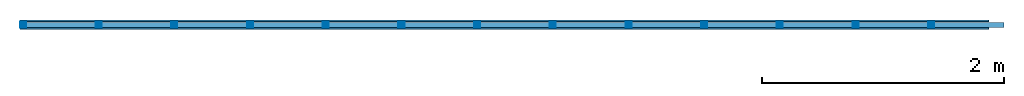
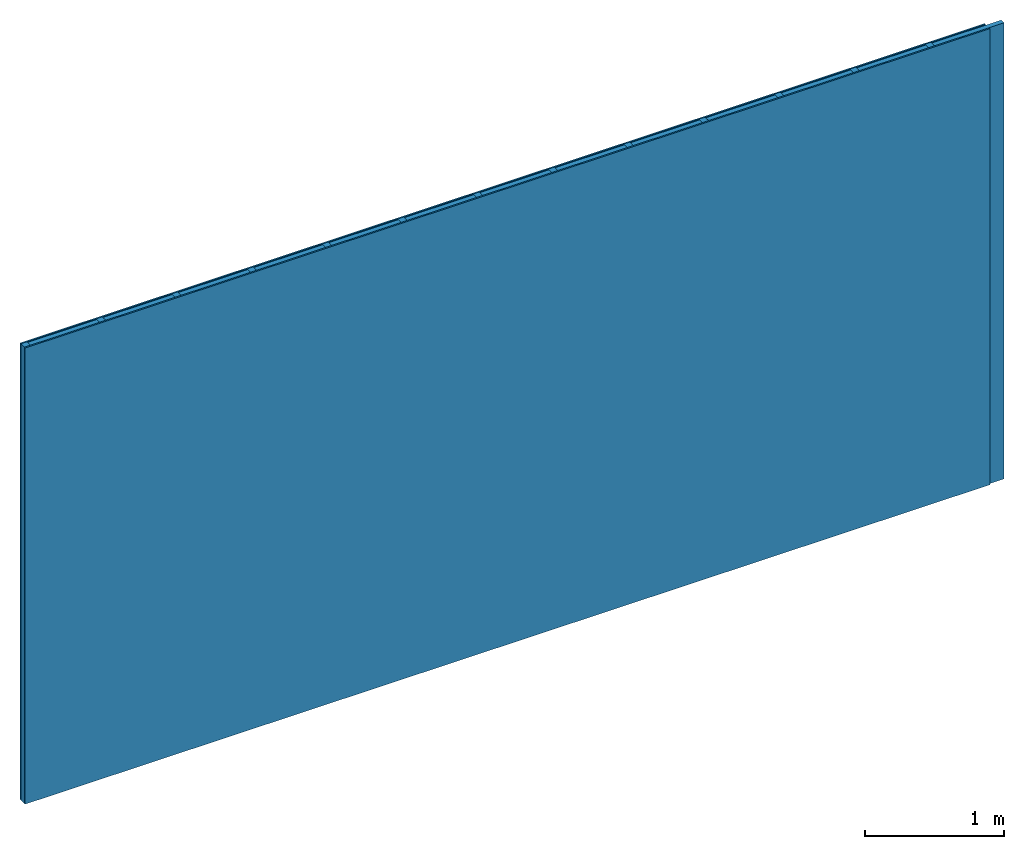
# One storey: 2 members, 2 plates, 1 element without a shape of its own.
"""IFC4 building model written with IfcOpenShell, lengths in metres."""

from ifc_helpers import new_model, si_unit, derived_unit, direction, frame, frame_2d, origin, origin_with_axes, place, context, project, spatial, rectangle, extrude, material, layer, layer_set, type_object, element, aggregate, save


model = new_model("IFC4")

# Units and contexts
plan_context = context("Plan", 3, precision=1e-05, world=origin(), true_north=direction((0.0, 1.0)))
model_context = context("Model", 3, precision=1e-05, world=origin(), true_north=direction((0.0, 1.0)))
ifc_project = project(units=[si_unit("LENGTHUNIT", "METRE"), derived_unit("SOUNDPRESSUREUNIT", [(si_unit("PRESSUREUNIT", "PASCAL", prefix="MICRO"), 0)]), si_unit("ENERGYUNIT", "JOULE", prefix="MEGA"), si_unit("MASSUNIT", "GRAM", prefix="KILO"), derived_unit("THERMALTRANSMITTANCEUNIT", [(si_unit("POWERUNIT", "WATT"), 1), (si_unit("AREAUNIT", "SQUARE_METRE"), -1), (si_unit("THERMODYNAMICTEMPERATUREUNIT", "KELVIN"), -1)]), derived_unit("AREADENSITYUNIT", [(si_unit("MASSUNIT", "GRAM", prefix="KILO"), 1), (si_unit("AREAUNIT", "SQUARE_METRE"), -1)]), derived_unit("USERDEFINED", [(si_unit("ENERGYUNIT", "JOULE", prefix="MEGA"), 1), (si_unit("AREAUNIT", "SQUARE_METRE"), -1)])], contexts=[plan_context, model_context])

# Site, building, storey
site = spatial("IfcSite", under=ifc_project)
building_placement = place(None, origin())
building = spatial("IfcBuilding", under=site, at=building_placement)
storey_placement = place(building_placement, origin())
storey = spatial("IfcBuildingStorey", under=building, at=storey_placement)

# Wall, members, plates
ifc_material_1 = material(Name="joints", Category="04.017")
ifc_layer_1 = layer(ifc_material_1, 0.0, Name="Surface")
ifc_material_2 = material(Category="03.008")
ifc_layer_2 = layer(ifc_material_2, 0.0125, Name="1st layer")
ifc_material_3 = material(Name="of the art")
ifc_layer_3 = layer(ifc_material_3, 0.0, Name="Bond")
ifc_layer_4 = layer(None, 0.05, Name="Support")
ifc_layer_5 = layer(ifc_material_3, 0.0, Name="Bond")
ifc_material_4 = material(Name="Plasterboard type A", Category="03.008")
ifc_layer_6 = layer(ifc_material_4, 0.0125, Name="1st layer")
ifc_layer_7 = layer(ifc_material_1, 0.0, Name="Surface")
ifc_layer_set = layer_set([ifc_layer_1, ifc_layer_2, ifc_layer_3, ifc_layer_4, ifc_layer_5, ifc_layer_6, ifc_layer_7])
wall_type = type_object("IfcWallType", Name="C0456", PredefinedType="NOTDEFINED", material=ifc_layer_set)
wall_placement = place(None, frame((0.0, 0.0, 0.0), z_axis=(0.0, -1.0, 0.0), x_axis=(1.0, 0.0, 0.0)))
wall = element("IfcWall", 1, at=wall_placement, inside=storey, type_object=wall_type, material=ifc_layer_set, Name="Wall #1")
ifc_material_5 = material()
member_1_placement = place(wall_placement, origin())
member_1 = element("IfcMember", 2, at=member_1_placement, material=ifc_material_5, Name="Support", context=plan_context, shape_type="SweptSolid", body=[
    extrude(rectangle(XDim=0.05, YDim=0.05, at=frame_2d((0.025, 0.025), x_axis=(1.0, 0.0))), frame((0.0, 4.0, 0.0125), z_axis=(0.0, -1.0, 0.0), x_axis=(1.0, 0.0, 0.0)), (0.0, 0.0, 1.0), 4.0),
    extrude(rectangle(XDim=0.05, YDim=0.05, at=frame_2d((0.025, 0.025), x_axis=(1.0, 0.0))), frame((0.625, 4.0, 0.0125), z_axis=(0.0, -1.0, 0.0), x_axis=(1.0, 0.0, 0.0)), (0.0, 0.0, 1.0), 4.0),
    extrude(rectangle(XDim=0.05, YDim=0.05, at=frame_2d((0.025, 0.025), x_axis=(1.0, 0.0))), frame((1.25, 4.0, 0.0125), z_axis=(0.0, -1.0, 0.0), x_axis=(1.0, 0.0, 0.0)), (0.0, 0.0, 1.0), 4.0),
    extrude(rectangle(XDim=0.05, YDim=0.05, at=frame_2d((0.025, 0.025), x_axis=(1.0, 0.0))), frame((1.875, 4.0, 0.0125), z_axis=(0.0, -1.0, 0.0), x_axis=(1.0, 0.0, 0.0)), (0.0, 0.0, 1.0), 4.0),
    extrude(rectangle(XDim=0.05, YDim=0.05, at=frame_2d((0.025, 0.025), x_axis=(1.0, 0.0))), frame((2.5, 4.0, 0.0125), z_axis=(0.0, -1.0, 0.0), x_axis=(1.0, 0.0, 0.0)), (0.0, 0.0, 1.0), 4.0),
    extrude(rectangle(XDim=0.05, YDim=0.05, at=frame_2d((0.025, 0.025), x_axis=(1.0, 0.0))), frame((3.125, 4.0, 0.0125), z_axis=(0.0, -1.0, 0.0), x_axis=(1.0, 0.0, 0.0)), (0.0, 0.0, 1.0), 4.0),
    extrude(rectangle(XDim=0.05, YDim=0.05, at=frame_2d((0.025, 0.025), x_axis=(1.0, 0.0))), frame((3.75, 4.0, 0.0125), z_axis=(0.0, -1.0, 0.0), x_axis=(1.0, 0.0, 0.0)), (0.0, 0.0, 1.0), 4.0),
    extrude(rectangle(XDim=0.05, YDim=0.05, at=frame_2d((0.025, 0.025), x_axis=(1.0, 0.0))), frame((4.375, 4.0, 0.0125), z_axis=(0.0, -1.0, 0.0), x_axis=(1.0, 0.0, 0.0)), (0.0, 0.0, 1.0), 4.0),
    extrude(rectangle(XDim=0.05, YDim=0.05, at=frame_2d((0.025, 0.025), x_axis=(1.0, 0.0))), frame((5.0, 4.0, 0.0125), z_axis=(0.0, -1.0, 0.0), x_axis=(1.0, 0.0, 0.0)), (0.0, 0.0, 1.0), 4.0),
    extrude(rectangle(XDim=0.05, YDim=0.05, at=frame_2d((0.025, 0.025), x_axis=(1.0, 0.0))), frame((5.625, 4.0, 0.0125), z_axis=(0.0, -1.0, 0.0), x_axis=(1.0, 0.0, 0.0)), (0.0, 0.0, 1.0), 4.0),
    extrude(rectangle(XDim=0.05, YDim=0.05, at=frame_2d((0.025, 0.025), x_axis=(1.0, 0.0))), frame((6.25, 4.0, 0.0125), z_axis=(0.0, -1.0, 0.0), x_axis=(1.0, 0.0, 0.0)), (0.0, 0.0, 1.0), 4.0),
    extrude(rectangle(XDim=0.05, YDim=0.05, at=frame_2d((0.025, 0.025), x_axis=(1.0, 0.0))), frame((6.875, 4.0, 0.0125), z_axis=(0.0, -1.0, 0.0), x_axis=(1.0, 0.0, 0.0)), (0.0, 0.0, 1.0), 4.0),
    extrude(rectangle(XDim=0.05, YDim=0.05, at=frame_2d((0.025, 0.025), x_axis=(1.0, 0.0))), frame((7.5, 4.0, 0.0125), z_axis=(0.0, -1.0, 0.0), x_axis=(1.0, 0.0, 0.0)), (0.0, 0.0, 1.0), 4.0),
])
ifc_material_6 = material()
member_2_placement = place(wall_placement, origin())
member_2 = element("IfcMember", 3, at=member_2_placement, material=ifc_material_6, Name="Cavity", context=plan_context, shape_type="SweptSolid", body=[
    extrude(rectangle(XDim=0.575, YDim=0.04, at=frame_2d((0.2875, 0.02), x_axis=(1.0, 0.0))), frame((0.05, 4.0, 0.0225), z_axis=(0.0, -1.0, 0.0), x_axis=(1.0, 0.0, 0.0)), (0.0, 0.0, 1.0), 4.0),
    extrude(rectangle(XDim=0.575, YDim=0.04, at=frame_2d((0.2875, 0.02), x_axis=(1.0, 0.0))), frame((0.675, 4.0, 0.0225), z_axis=(0.0, -1.0, 0.0), x_axis=(1.0, 0.0, 0.0)), (0.0, 0.0, 1.0), 4.0),
    extrude(rectangle(XDim=0.575, YDim=0.04, at=frame_2d((0.2875, 0.02), x_axis=(1.0, 0.0))), frame((1.3, 4.0, 0.0225), z_axis=(0.0, -1.0, 0.0), x_axis=(1.0, 0.0, 0.0)), (0.0, 0.0, 1.0), 4.0),
    extrude(rectangle(XDim=0.575, YDim=0.04, at=frame_2d((0.2875, 0.02), x_axis=(1.0, 0.0))), frame((1.925, 4.0, 0.0225), z_axis=(0.0, -1.0, 0.0), x_axis=(1.0, 0.0, 0.0)), (0.0, 0.0, 1.0), 4.0),
    extrude(rectangle(XDim=0.575, YDim=0.04, at=frame_2d((0.2875, 0.02), x_axis=(1.0, 0.0))), frame((2.55, 4.0, 0.0225), z_axis=(0.0, -1.0, 0.0), x_axis=(1.0, 0.0, 0.0)), (0.0, 0.0, 1.0), 4.0),
    extrude(rectangle(XDim=0.575, YDim=0.04, at=frame_2d((0.2875, 0.02), x_axis=(1.0, 0.0))), frame((3.175, 4.0, 0.0225), z_axis=(0.0, -1.0, 0.0), x_axis=(1.0, 0.0, 0.0)), (0.0, 0.0, 1.0), 4.0),
    extrude(rectangle(XDim=0.575, YDim=0.04, at=frame_2d((0.2875, 0.02), x_axis=(1.0, 0.0))), frame((3.8, 4.0, 0.0225), z_axis=(0.0, -1.0, 0.0), x_axis=(1.0, 0.0, 0.0)), (0.0, 0.0, 1.0), 4.0),
    extrude(rectangle(XDim=0.575, YDim=0.04, at=frame_2d((0.2875, 0.02), x_axis=(1.0, 0.0))), frame((4.425, 4.0, 0.0225), z_axis=(0.0, -1.0, 0.0), x_axis=(1.0, 0.0, 0.0)), (0.0, 0.0, 1.0), 4.0),
    extrude(rectangle(XDim=0.575, YDim=0.04, at=frame_2d((0.2875, 0.02), x_axis=(1.0, 0.0))), frame((5.05, 4.0, 0.0225), z_axis=(0.0, -1.0, 0.0), x_axis=(1.0, 0.0, 0.0)), (0.0, 0.0, 1.0), 4.0),
    extrude(rectangle(XDim=0.575, YDim=0.04, at=frame_2d((0.2875, 0.02), x_axis=(1.0, 0.0))), frame((5.675, 4.0, 0.0225), z_axis=(0.0, -1.0, 0.0), x_axis=(1.0, 0.0, 0.0)), (0.0, 0.0, 1.0), 4.0),
    extrude(rectangle(XDim=0.575, YDim=0.04, at=frame_2d((0.2875, 0.02), x_axis=(1.0, 0.0))), frame((6.3, 4.0, 0.0225), z_axis=(0.0, -1.0, 0.0), x_axis=(1.0, 0.0, 0.0)), (0.0, 0.0, 1.0), 4.0),
    extrude(rectangle(XDim=0.575, YDim=0.04, at=frame_2d((0.2875, 0.02), x_axis=(1.0, 0.0))), frame((6.925, 4.0, 0.0225), z_axis=(0.0, -1.0, 0.0), x_axis=(1.0, 0.0, 0.0)), (0.0, 0.0, 1.0), 4.0),
    extrude(rectangle(XDim=0.575, YDim=0.04, at=frame_2d((0.2875, 0.02), x_axis=(1.0, 0.0))), frame((7.55, 4.0, 0.0225), z_axis=(0.0, -1.0, 0.0), x_axis=(1.0, 0.0, 0.0)), (0.0, 0.0, 1.0), 4.0),
])
plate_1_placement = place(wall_placement, origin())
plate_1 = element("IfcPlate", 4, at=plate_1_placement, material=ifc_material_2, Name="1st layer", context=plan_context, shape_type="SweptSolid", body=[
    extrude(rectangle(XDim=8.0, YDim=4.0, at=frame_2d((4.0, 2.0), x_axis=(1.0, 0.0))), origin_with_axes(), (0.0, 0.0, 1.0), 0.0125),
])
plate_2_placement = place(wall_placement, origin())
plate_2 = element("IfcPlate", 5, at=plate_2_placement, material=ifc_material_4, Name="1st layer", context=plan_context, shape_type="SweptSolid", body=[
    extrude(rectangle(XDim=8.0, YDim=4.0, at=frame_2d((4.0, 2.0), x_axis=(1.0, 0.0))), frame((0.0, 0.0, 0.0625), z_axis=(0.0, 0.0, 1.0), x_axis=(1.0, 0.0, 0.0)), (0.0, 0.0, 1.0), 0.0125),
])
aggregate(wall, [plate_1, member_1, member_2, plate_2])

save(model, "model.ifc")
